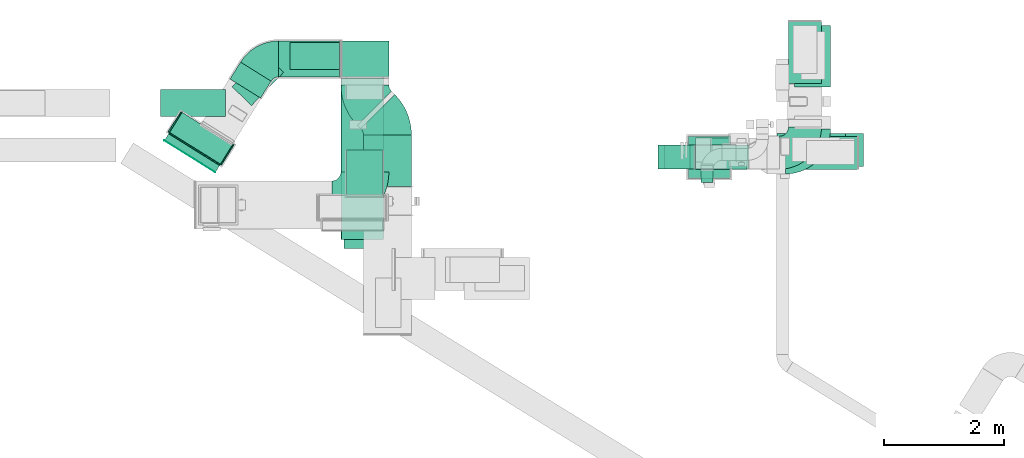
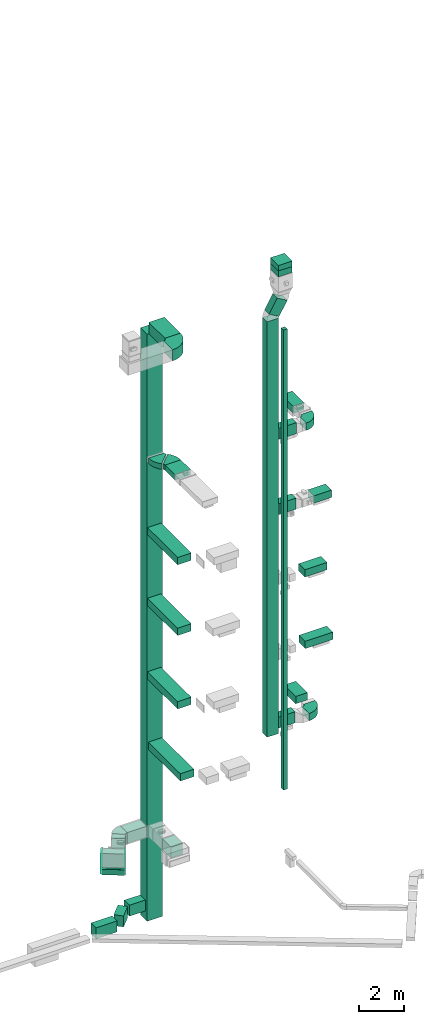
# One storey, part 6 of 29: 27 flow segments, 10 flow fittings, 1 flow terminal.
"""IFC2X3 building model written with IfcOpenShell, lengths in millimetres."""

from ifc_helpers import new_model, entity, si_unit, converted_unit, derived_unit, direction, frame, frame_2d, origin, origin_2d_with_axis, place, context, subcontext, project, spatial, polyline, circle_curve, parameter, trimmed, segment, composite_curve, rectangle, outline, extrude, faceted_brep, source, transform, mapped, material, type_object, type_shapes, element, save


model = new_model("IFC2X3")

# Units and contexts
model_context = context("Model", 3, precision=0.01, world=origin(), true_north=direction((6.12303176911189e-17, 1.0)))
body_context = subcontext(model_context, "Body", "Model", "MODEL_VIEW")
ifc_project = project(units=[si_unit("LENGTHUNIT", "METRE", prefix="MILLI"), si_unit("AREAUNIT", "SQUARE_METRE"), si_unit("VOLUMEUNIT", "CUBIC_METRE"), converted_unit("PLANEANGLEUNIT", "DEGREE", entity("IfcRatioMeasure", 0.0174532925199433), si_unit("PLANEANGLEUNIT", "RADIAN"), dimensions=[0, 0, 0, 0, 0, 0, 0]), si_unit("MASSUNIT", "GRAM", prefix="KILO"), derived_unit("MASSDENSITYUNIT", [(si_unit("MASSUNIT", "GRAM", prefix="KILO"), 1), (si_unit("LENGTHUNIT", "METRE"), -3)]), derived_unit("MOMENTOFINERTIAUNIT", [(si_unit("LENGTHUNIT", "METRE"), 4)]), si_unit("TIMEUNIT", "SECOND"), si_unit("FREQUENCYUNIT", "HERTZ"), si_unit("THERMODYNAMICTEMPERATUREUNIT", "DEGREE_CELSIUS"), derived_unit("THERMALTRANSMITTANCEUNIT", [(si_unit("MASSUNIT", "GRAM", prefix="KILO"), 1), (si_unit("THERMODYNAMICTEMPERATUREUNIT", "KELVIN"), -1), (si_unit("TIMEUNIT", "SECOND"), -3)]), derived_unit("VOLUMETRICFLOWRATEUNIT", [(si_unit("LENGTHUNIT", "METRE"), 3), (si_unit("TIMEUNIT", "SECOND"), -1)]), derived_unit("MASSFLOWRATEUNIT", [(si_unit("MASSUNIT", "GRAM", prefix="KILO"), 1), (si_unit("TIMEUNIT", "SECOND"), -1)]), derived_unit("ROTATIONALFREQUENCYUNIT", [(si_unit("TIMEUNIT", "SECOND"), -1)]), si_unit("ELECTRICCURRENTUNIT", "AMPERE"), si_unit("ELECTRICVOLTAGEUNIT", "VOLT"), si_unit("POWERUNIT", "WATT"), si_unit("FORCEUNIT", "NEWTON", prefix="KILO"), si_unit("ILLUMINANCEUNIT", "LUX"), si_unit("LUMINOUSFLUXUNIT", "LUMEN"), si_unit("LUMINOUSINTENSITYUNIT", "CANDELA"), derived_unit("USERDEFINED", [(si_unit("MASSUNIT", "GRAM", prefix="KILO"), -1), (si_unit("LENGTHUNIT", "METRE"), -2), (si_unit("TIMEUNIT", "SECOND"), 3), (si_unit("LUMINOUSFLUXUNIT", "LUMEN"), 1)]), derived_unit("LINEARVELOCITYUNIT", [(si_unit("LENGTHUNIT", "METRE"), 1), (si_unit("TIMEUNIT", "SECOND"), -1)]), si_unit("PRESSUREUNIT", "PASCAL"), derived_unit("USERDEFINED", [(si_unit("LENGTHUNIT", "METRE"), -2), (si_unit("MASSUNIT", "GRAM", prefix="KILO"), 1), (si_unit("TIMEUNIT", "SECOND"), -2)]), derived_unit("LINEARFORCEUNIT", [(si_unit("MASSUNIT", "GRAM", prefix="KILO"), 1), (si_unit("LENGTHUNIT", "METRE"), 1), (si_unit("TIMEUNIT", "SECOND"), -2), (si_unit("LENGTHUNIT", "METRE"), -1)]), derived_unit("PLANARFORCEUNIT", [(si_unit("MASSUNIT", "GRAM", prefix="KILO"), 1), (si_unit("LENGTHUNIT", "METRE"), 1), (si_unit("TIMEUNIT", "SECOND"), -2), (si_unit("LENGTHUNIT", "METRE"), -2)])], contexts=[model_context])

# Site, building, storey
site_placement = place(None, frame((0.0, -0.00077364408347762, 0.0)))
site = spatial("IfcSite", under=ifc_project, at=site_placement, CompositionType="ELEMENT")
building_placement = place(site_placement, origin())
building = spatial("IfcBuilding", under=site, at=building_placement, CompositionType="ELEMENT")
storey_placement = place(building_placement, origin())
storey = spatial("IfcBuildingStorey", under=building, at=storey_placement, CompositionType="ELEMENT", Elevation=0.0)

# Flow segments
duct_segment_type_1 = type_object("IfcDuctSegmentType", PredefinedType="NOTDEFINED")
flow_segment_1_placement = place(storey_placement, frame((10049.7340134019, 14594.0835453812, 7185.13492759623)))
element("IfcFlowSegment", 1, at=flow_segment_1_placement, inside=storey, type_object=duct_segment_type_1, context=body_context, shape_type="SweptSolid", body=[
    extrude(rectangle(XDim=896.28958332103, YDim=400.0, at=origin_2d_with_axis()), frame((448.144791660515, 200.0, 0.0), z_axis=(0.0, 0.0, 1.0), x_axis=(-1.0, 0.0, 0.0)), (0.0, 0.0, 1.0), 600.0),
])
flow_segment_2_placement = place(storey_placement, frame((10049.7340134019, 14469.5640511156, 18900.0)))
element("IfcFlowSegment", 2, at=flow_segment_2_placement, inside=storey, type_object=duct_segment_type_1, context=body_context, shape_type="SweptSolid", body=[
    extrude(rectangle(XDim=860.000000000108, YDim=400.0, at=origin_2d_with_axis()), frame((430.0, 200.0, 0.0)), (0.0, 0.0, 1.0), 599.999999999998),
])
flow_segment_3_placement = place(storey_placement, frame((11848.4871552699, 14469.5640511154, 18900.0)))
element("IfcFlowSegment", 3, at=flow_segment_3_placement, inside=storey, type_object=duct_segment_type_1, context=body_context, shape_type="SweptSolid", body=[
    extrude(rectangle(XDim=897.282341040552, YDim=550.000000000001, at=frame_2d((-1.08002495835535e-12, 0.0), x_axis=(1.0, 0.0))), frame((448.641170520277, 275.0, 0.0)), (0.0, 0.0, 1.0), 400.0),
])
flow_segment_4_placement = place(storey_placement, frame((10049.7340134019, 14472.5640511155, 23000.0)))
element("IfcFlowSegment", 4, at=flow_segment_4_placement, inside=storey, type_object=duct_segment_type_1, context=body_context, shape_type="SweptSolid", body=[
    extrude(rectangle(XDim=896.035482908388, YDim=400.0, at=frame_2d((1.08002495835535e-12, 1.09423581307055e-12), x_axis=(1.0, 0.0))), frame((448.017741454193, 200.0, 0.0)), (0.0, 0.0, 1.0), 600.000000000002),
])
flow_segment_5_placement = place(storey_placement, frame((11599.6422610433, 15901.4858452885, 23000.0)))
element("IfcFlowSegment", 5, at=flow_segment_5_placement, inside=storey, type_object=duct_segment_type_1, context=body_context, shape_type="SweptSolid", body=[
    extrude(rectangle(XDim=1032.28234104056, YDim=550.000000000001, at=frame_2d((1.08002495835535e-12, 0.0), x_axis=(1.0, 0.0))), frame((275.0, 516.141170520279, 0.0), z_axis=(0.0, 0.0, 1.0), x_axis=(0.0, 1.0, 0.0)), (0.0, 0.0, 1.0), 399.999999999996),
])
flow_segment_6_placement = place(storey_placement, frame((10144.7174683872, 14250.8402530396, 4000.0)))
element("IfcFlowSegment", 6, at=flow_segment_6_placement, inside=storey, type_object=duct_segment_type_1, context=body_context, shape_type="SweptSolid", body=[
    extrude(rectangle(XDim=199.999999999998, YDim=200.0, at=frame_2d((1.08713038571295e-12, 0.0), x_axis=(1.0, 0.0))), frame((100.0, 100.0, 0.0), z_axis=(0.0, 0.0, 1.0), x_axis=(0.0, -1.0, 0.0)), (0.0, 0.0, 1.0), 25050.0),
])
flow_segment_7_placement = place(storey_placement, frame((9429.73401340191, 14472.5640511154, 7000.0)))
element("IfcFlowSegment", 7, at=flow_segment_7_placement, inside=storey, type_object=duct_segment_type_1, context=body_context, shape_type="SweptSolid", body=[
    extrude(rectangle(XDim=400.0, YDim=600.0, at=frame_2d((0.0, 1.08002495835535e-12), x_axis=(1.0, 0.0))), frame((300.0, 200.0, 0.0), z_axis=(0.0, 0.0, 1.0), x_axis=(0.0, 1.0, 0.0)), (0.0, 0.0, 1.0), 22618.0236689535),
])
flow_segment_8_placement = place(storey_placement, frame((1285.71170920467, 14551.0540027881, 2050.0)))
element("IfcFlowSegment", 8, at=flow_segment_8_placement, inside=storey, type_object=duct_segment_type_1, context=body_context, shape_type="SweptSolid", body=[
    extrude(rectangle(XDim=1000.0, YDim=400.000000000001, at=frame_2d((-5.6843418860808e-13, 9.2370555648813e-13), x_axis=(1.0, 0.0))), frame((530.007900914171, 434.569251383529, 0.0), z_axis=(0.0, 0.0, 1.0), x_axis=(0.848048096097044, -0.529919264328235, 0.0)), (0.0, 0.0, 1.0), 1100.0),
])
flow_segment_9_placement = place(storey_placement, frame((11423.6279861459, 14520.0835453812, 11100.0)))
element("IfcFlowSegment", 9, at=flow_segment_9_placement, inside=storey, type_object=duct_segment_type_1, context=body_context, shape_type="SweptSolid", body=[
    extrude(rectangle(XDim=1424.85916912395, YDim=550.000000000001, at=origin_2d_with_axis()), frame((712.429584561975, 275.0, 0.0)), (0.0, 0.0, 1.0), 400.0),
])
flow_segment_10_placement = place(storey_placement, frame((11408.6279789287, 14519.0835453812, 15000.0)))
element("IfcFlowSegment", 10, at=flow_segment_10_placement, inside=storey, type_object=duct_segment_type_1, context=body_context, shape_type="SweptSolid", body=[
    extrude(rectangle(XDim=1142.14151738165, YDim=550.000000000001, at=frame_2d((0.0, 2.1600499167107e-12), x_axis=(1.0, 0.0))), frame((571.070758690827, 275.0, 0.0), z_axis=(0.0, 0.0, 1.0), x_axis=(-1.0, 0.0, 0.0)), (0.0, 0.0, 1.0), 400.0),
])
flow_segment_11_placement = place(storey_placement, frame((11700.2194386705, 15840.3805781062, 7200.0)))
element("IfcFlowSegment", 11, at=flow_segment_11_placement, inside=storey, type_object=duct_segment_type_1, context=body_context, shape_type="SweptSolid", body=[
    extrude(rectangle(XDim=1025.0, YDim=600.0, at=frame_2d((0.0, 1.08002495835535e-12), x_axis=(1.0, 0.0))), frame((300.0, 512.5, 0.0), z_axis=(0.0, 0.0, 1.0), x_axis=(0.0, 1.0, 0.0)), (0.0, 0.0, 1.0), 400.0),
])
flow_segment_12_placement = place(storey_placement, frame((9532.39994495478, 14472.5640511154, 29693.7755280271)))
element("IfcFlowSegment", 12, at=flow_segment_12_placement, inside=storey, type_object=duct_segment_type_1, context=body_context, shape_type="SweptSolid", body=[
    extrude(rectangle(XDim=600.000000000002, YDim=400.000000000002, at=frame_2d((-1.09423581307055e-12, 9.37916411203332e-13), x_axis=(0.0, 1.0))), frame((258.933627378855, 200.0, 151.503718147211), z_axis=(0.505012393824036, 0.0, 0.863112091262842), x_axis=(0.0, 1.0, 0.0)), (0.0, 0.0, 1.0), 845.129520297064),
])
flow_segment_13_placement = place(storey_placement, frame((9929.73401340183, 14322.5640511154, 31980.0)))
element("IfcFlowSegment", 13, at=flow_segment_13_placement, inside=storey, type_object=duct_segment_type_1, context=body_context, shape_type="SweptSolid", body=[
    extrude(rectangle(XDim=700.000000000001, YDim=699.999999999999, at=frame_2d((-1.08002495835535e-12, 0.0), x_axis=(1.0, 0.0))), frame((350.0, 350.0, 0.0), z_axis=(0.0, 0.0, 1.0), x_axis=(0.0, 1.0, 0.0)), (0.0, 0.0, 1.0), 320.64365169538),
])
duct_segment_type_2 = type_object("IfcDuctSegmentType", PredefinedType="NOTDEFINED")
flow_segment_14_placement = place(storey_placement, frame((4143.3305169552, 14427.5681314502, 30000.0)))
element("IfcFlowSegment", 14, at=flow_segment_14_placement, inside=storey, type_object=duct_segment_type_2, context=body_context, shape_type="SweptSolid", body=[
    extrude(rectangle(XDim=1432.40750074229, YDim=800.0, at=frame_2d((-1.13686837721616e-12, 0.0), x_axis=(1.0, 0.0))), frame((400.0, 716.203750371147, 0.0), z_axis=(0.0, 0.0, 1.0), x_axis=(0.0, -1.0, 0.0)), (0.0, 0.0, 1.0), 600.000000000002),
])
flow_segment_15_placement = place(storey_placement, frame((4143.33051695439, 16009.975632191, -2100.0)))
element("IfcFlowSegment", 15, at=flow_segment_15_placement, inside=storey, type_object=duct_segment_type_2, context=body_context, shape_type="SweptSolid", body=[
    extrude(rectangle(XDim=599.999999999998, YDim=800.0, at=frame_2d((1.08002495835535e-12, 0.0), x_axis=(1.0, 0.0))), frame((400.0, 300.0, 0.0), z_axis=(0.0, 0.0, 1.0), x_axis=(0.0, 1.0, 0.0)), (0.0, 0.0, 1.0), 31950.0),
])
flow_segment_16_placement = place(storey_placement, frame((4519.66175990126, 14181.608746557, 22900.0)))
element("IfcFlowSegment", 16, at=flow_segment_16_placement, inside=storey, type_object=duct_segment_type_2, context=body_context, shape_type="SweptSolid", body=[
    extrude(rectangle(XDim=862.182540694804, YDim=800.0, at=frame_2d((1.08002495835535e-12, -5.40012479177676e-13), x_axis=(1.0, 0.0))), frame((400.0, 431.091270347508, 0.0), z_axis=(0.0, 0.0, 1.0), x_axis=(0.0, 1.0, 0.0)), (0.0, 0.0, 1.0), 300.000000000001),
])
flow_segment_17_placement = place(storey_placement, frame((4150.45036991614, 13299.6581969188, 18950.0)))
element("IfcFlowSegment", 17, at=flow_segment_17_placement, inside=storey, type_object=duct_segment_type_2, context=body_context, shape_type="SweptSolid", body=[
    extrude(rectangle(XDim=2690.31743527313, YDim=700.0, at=frame_2d((0.0, -2.55795384873636e-13), x_axis=(1.0, 0.0))), frame((350.0, 1345.15871763657, 0.0), z_axis=(0.0, 0.0, 1.0), x_axis=(0.0, 1.0, 0.0)), (0.0, 0.0, 1.0), 400.0),
])
flow_segment_18_placement = place(storey_placement, frame((4199.45036991613, 13150.4683688133, 7250.0)))
element("IfcFlowSegment", 18, at=flow_segment_18_placement, inside=storey, type_object=duct_segment_type_2, context=body_context, shape_type="SweptSolid", body=[
    extrude(rectangle(XDim=2839.50726337812, YDim=700.0, at=frame_2d((-1.13686837721616e-12, 5.40012479177676e-13), x_axis=(1.0, 0.0))), frame((350.0, 1419.75363168906, 0.0), z_axis=(0.0, 0.0, 1.0), x_axis=(0.0, 1.0, 0.0)), (0.0, 0.0, 1.0), 400.0),
])
flow_segment_19_placement = place(storey_placement, frame((4149.45036991614, 13299.6581969188, 11100.0)))
element("IfcFlowSegment", 19, at=flow_segment_19_placement, inside=storey, type_object=duct_segment_type_2, context=body_context, shape_type="SweptSolid", body=[
    extrude(rectangle(XDim=2690.31743527277, YDim=700.0, at=frame_2d((0.0, -2.55795384873636e-13), x_axis=(1.0, 0.0))), frame((350.0, 1345.15871763639, 0.0), z_axis=(0.0, 0.0, 1.0), x_axis=(0.0, 1.0, 0.0)), (0.0, 0.0, 1.0), 400.0),
])
flow_segment_20_placement = place(storey_placement, frame((4150.45036991614, 13299.6581969188, 15100.0)))
element("IfcFlowSegment", 20, at=flow_segment_20_placement, inside=storey, type_object=duct_segment_type_2, context=body_context, shape_type="SweptSolid", body=[
    extrude(rectangle(XDim=2690.31743527295, YDim=700.0, at=frame_2d((-1.13686837721616e-12, -2.55795384873636e-13), x_axis=(1.0, 0.0))), frame((350.0, 1345.15871763648, 0.0), z_axis=(0.0, 0.0, 1.0), x_axis=(0.0, 1.0, 0.0)), (0.0, 0.0, 1.0), 400.0),
])
flow_segment_21_placement = place(storey_placement, frame((4238.73846384671, 14052.5, 2500.0)))
element("IfcFlowSegment", 21, at=flow_segment_21_placement, inside=storey, type_object=duct_segment_type_2, context=body_context, shape_type="SweptSolid", body=[
    extrude(rectangle(XDim=738.844290776113, YDim=600.0, at=origin_2d_with_axis()), frame((300.0, 369.422145388058, 0.0), z_axis=(0.0, 0.0, 1.0), x_axis=(0.0, -1.0, 0.0)), (0.0, 0.0, 1.0), 600.0),
])
flow_segment_22_placement = place(storey_placement, frame((3108.61579884427, 16009.9756321925, 2485.0)))
element("IfcFlowSegment", 22, at=flow_segment_22_placement, inside=storey, type_object=duct_segment_type_2, context=body_context, shape_type="SweptSolid", body=[
    extrude(rectangle(XDim=1014.71471811025, YDim=600.0, at=frame_2d((0.0, 1.08002495835535e-12), x_axis=(1.0, 0.0))), frame((507.357359055123, 300.0, 0.0), z_axis=(0.0, 0.0, 1.0), x_axis=(-1.0, 0.0, 0.0)), (0.0, 0.0, 1.0), 600.0),
])
flow_segment_23_placement = place(storey_placement, frame((1205.05402974284, 14422.633316354, 2100.0)))
element("IfcFlowSegment", 23, at=flow_segment_23_placement, inside=storey, type_object=duct_segment_type_2, context=body_context, shape_type="SweptSolid", body=[
    extrude(rectangle(XDim=131.648976761312, YDim=1000.0, at=frame_2d((9.16600129130529e-13, 5.6843418860808e-13), x_axis=(1.0, 0.0))), frame((458.905712529418, 320.781964168288, 0.0), z_axis=(0.0, 0.0, 1.0), x_axis=(0.529919264233203, 0.848048096156427, 0.0)), (0.0, 0.0, 1.0), 300.0),
])
flow_segment_24_placement = place(storey_placement, frame((3296.5333327933, 16131.8209502161, -1600.0)))
element("IfcFlowSegment", 24, at=flow_segment_24_placement, inside=storey, type_object=duct_segment_type_2, context=body_context, shape_type="SweptSolid", body=[
    extrude(rectangle(XDim=826.797184161113, YDim=449.999999999999, at=frame_2d((-2.8421709430404e-13, 1.08002495835535e-12), x_axis=(1.0, 0.0))), frame((413.398592080557, 225.0, 0.0), z_axis=(0.0, 0.0, 1.0), x_axis=(-1.0, 0.0, 0.0)), (0.0, 0.0, 1.0), 600.0),
])
flow_segment_25_placement = place(storey_placement, frame((2331.18103775171, 15533.3070422821, -1600.0)))
element("IfcFlowSegment", 25, at=flow_segment_25_placement, inside=storey, type_object=duct_segment_type_2, context=body_context, shape_type="SweptSolid", body=[
    extrude(rectangle(XDim=768.361021095479, YDim=450.000000000001, at=frame_2d((9.66338120633736e-13, 5.54223333892878e-13), x_axis=(1.0, 0.0))), frame((428.725662495396, 432.65446510469, 0.0), z_axis=(0.0, 0.0, 1.0), x_axis=(-0.694658370458998, -0.719339800338651, 0.0)), (0.0, 0.0, 1.0), 600.0),
])
flow_segment_26_placement = place(storey_placement, frame((2297.27259299581, 15658.9134625432, 2485.0)))
element("IfcFlowSegment", 26, at=flow_segment_26_placement, inside=storey, type_object=duct_segment_type_2, context=body_context, shape_type="SweptSolid", body=[
    extrude(rectangle(XDim=330.818571009889, YDim=600.0, at=frame_2d((1.05160324892495e-12, 3.41060513164848e-13), x_axis=(1.0, 0.0))), frame((342.067995716955, 299.250808947712, 0.0), z_axis=(0.0, 0.0, 1.0), x_axis=(-0.529919264328237, -0.848048096097043, 0.0)), (0.0, 0.0, 1.0), 600.0),
])
flow_segment_27_placement = place(storey_placement, frame((1140.10630979671, 15350.1020645575, -1600.0)))
element("IfcFlowSegment", 27, at=flow_segment_27_placement, inside=storey, type_object=duct_segment_type_2, context=body_context, shape_type="SweptSolid", body=[
    extrude(rectangle(XDim=1083.1737579042, YDim=449.999999999999, at=frame_2d((5.6843418860808e-14, -1.08002495835535e-12), x_axis=(1.0, 0.0))), frame((541.586878952102, 225.0, 0.0), z_axis=(0.0, 0.0, 1.0), x_axis=(-1.0, 0.0, 0.0)), (0.0, 0.0, 1.0), 600.0),
])

# Flow fitting
ifc_material_1 = material()
duct_fitting_type_1 = type_object("IfcDuctFittingType", PredefinedType="NOTDEFINED", material=ifc_material_1)
shared_shape_1 = source(origin(), body_context, "Body", "SweptSolid", [
    extrude(outline(composite_curve([segment(polyline([(-525.0, -225.0), (75.0, -225.0)]), True, "CONTINUOUS"), segment(trimmed(circle_curve(frame_2d((225.0, -225.0), x_axis=(0.0, 1.0)), 150.0), [parameter(0.0)], [parameter(90.0)], True, "PARAMETER"), False, "CONTINUOUS"), segment(polyline([(225.0, -75.0), (225.0, 525.0)]), True, "CONTINUOUS"), segment(trimmed(circle_curve(frame_2d((225.0, -225.0), x_axis=(0.0, 1.0)), 750.0), [parameter(0.0)], [parameter(90.0)], True, "PARAMETER"), True, "CONTINUOUS")], self_intersect=False)), frame((-225.0, 225.0, -200.0), z_axis=(0.0, 0.0, 1.0), x_axis=(-1.0, 0.0, 0.0)), (0.0, 0.0, 1.0), 400.0),
])
type_shapes(duct_fitting_type_1, [shared_shape_1])
flow_fitting_1_placement = place(storey_placement, frame((12000.2194386704, 14694.0835453811, 7400.0)))
element("IfcFlowFitting", 28, at=flow_fitting_1_placement, inside=storey, type_object=duct_fitting_type_1, material=ifc_material_1, context=body_context, shape_type="MappedRepresentation", body=[
    mapped(shared_shape_1, transform((0.0, 0.0, 0.0), scale=1.0)),
])

# Flow terminal
ifc_material_2 = material()
air_terminal_type = type_object("IfcAirTerminalType", PredefinedType="NOTDEFINED", material=ifc_material_2)
shared_shape_2 = source(origin(), body_context, "Body", "SweptSolid", [
    extrude(rectangle(XDim=4.0, YDim=999.999999999999, at=origin_2d_with_axis()), frame((0.0, -2.0, -150.0), z_axis=(0.0, 0.0, 1.0), x_axis=(0.0, 1.0, 0.0)), (0.0, 0.0, 1.0), 300.000000000005),
])
type_shapes(air_terminal_type, [shared_shape_2])
flow_terminal_placement = place(storey_placement, frame((1629.07807782105, 14687.5929484706, 2250.0), z_axis=(0.0, 0.0, -1.0), x_axis=(-0.848048096156392, 0.52991926423326, 0.0)))
element("IfcFlowTerminal", 29, at=flow_terminal_placement, inside=storey, type_object=air_terminal_type, material=ifc_material_2, context=body_context, shape_type="MappedRepresentation", body=[
    mapped(shared_shape_2, transform((0.0, 0.0, 0.0), scale=1.0)),
])

# Flow fittings
duct_fitting_type_2 = type_object("IfcDuctFittingType", PredefinedType="NOTDEFINED", material=ifc_material_1)
shared_shape_3 = source(origin(), body_context, "Body", "SweptSolid", [
    extrude(outline(composite_curve([segment(polyline([(-675.0, -275.0), (125.0, -275.0)]), True, "CONTINUOUS"), segment(trimmed(circle_curve(frame_2d((275.0, -275.0), x_axis=(0.0, 1.0)), 150.0), [parameter(0.0)], [parameter(90.0)], True, "PARAMETER"), False, "CONTINUOUS"), segment(polyline([(275.0, -125.0), (275.0, 675.0)]), True, "CONTINUOUS"), segment(trimmed(circle_curve(frame_2d((275.0, -275.0), x_axis=(0.0, 1.0)), 950.0), [parameter(0.0)], [parameter(89.9999999999999)], True, "PARAMETER"), True, "CONTINUOUS")], self_intersect=False)), frame((-275.0, 275.0, -300.0), z_axis=(0.0, 0.0, 1.0), x_axis=(-1.0, 0.0, 0.0)), (0.0, 0.0, 1.0), 600.0),
])
type_shapes(duct_fitting_type_2, [shared_shape_3])
flow_fitting_2_placement = place(storey_placement, frame((4543.33051695519, 13877.5681314502, 30300.0)))
element("IfcFlowFitting", 30, at=flow_fitting_2_placement, inside=storey, type_object=duct_fitting_type_2, material=ifc_material_1, context=body_context, shape_type="MappedRepresentation", body=[
    mapped(shared_shape_3, transform((0.0, 0.0, 0.0), scale=1.0)),
])
duct_fitting_type_3 = type_object("IfcDuctFittingType", PredefinedType="NOTDEFINED", material=ifc_material_1)
shared_shape_4 = source(origin(), body_context, "Body", "SweptSolid", [
    extrude(rectangle(XDim=26.0960001120806, YDim=1000.0, at=frame_2d((-7.7715611723761e-13, -5.6843418860808e-14), x_axis=(1.0, 0.0))), frame((6.95199999999667, 0.0, -150.0)), (0.0, 0.0, 1.0), 300.0),
])
type_shapes(duct_fitting_type_3, [shared_shape_4])
flow_fitting_3_placement = place(storey_placement, frame((1709.43979203782, 14816.1985745446, 2250.0), z_axis=(0.0, 0.0, -1.0), x_axis=(-0.529919264233199, -0.84804809615643, 0.0)))
element("IfcFlowFitting", 31, at=flow_fitting_3_placement, inside=storey, type_object=duct_fitting_type_3, material=ifc_material_1, context=body_context, shape_type="MappedRepresentation", body=[
    mapped(shared_shape_4, transform((0.0, 0.0, 0.0), scale=1.0)),
])
duct_fitting_type_4 = type_object("IfcDuctFittingType", PredefinedType="NOTDEFINED", material=ifc_material_1)
shared_shape_5 = source(origin(), body_context, "Body", "SweptSolid", [
    extrude(rectangle(XDim=24.9999999999999, YDim=400.0, at=frame_2d((-1.63424829224823e-13, 0.0), x_axis=(1.0, 0.0))), frame((12.5000000000061, 0.0, -550.0)), (0.0, 0.0, 1.0), 1100.0),
])
type_shapes(duct_fitting_type_4, [shared_shape_5])
for number, where, z_axis, x_axis in (
    (32, (1391.69556207032, 15250.5828863358, 2600.0), (0.0, 0.0, 1.0), (-0.848048096097044, 0.529919264328235, 0.0)),
    (33, (2239.74365816737, 14720.6636220076, 2600.0), (0.0, 0.0, 1.0), (0.848048096097044, -0.529919264328235, 0.0)),
):
    element("IfcFlowFitting", number, at=place(storey_placement, frame(where, z_axis=z_axis, x_axis=x_axis)), inside=storey, type_object=duct_fitting_type_4, material=ifc_material_1, context=body_context, shape_type="MappedRepresentation", body=[
        mapped(shared_shape_5, transform((0.0, 0.0, 0.0), scale=1.0)),
    ])
duct_fitting_type_5 = type_object("IfcDuctFittingType", PredefinedType="NOTDEFINED", material=ifc_material_1)
shared_shape_6 = source(origin(), body_context, "Body", "SweptSolid", [
    extrude(outline(composite_curve([segment(polyline([(-405.768165526146, -190.810821621834), (194.231834473855, -190.810821621834)]), True, "CONTINUOUS"), segment(trimmed(circle_curve(frame_2d((344.231834473854, -190.810821621834), x_axis=(-0.529919264328242, 0.848048096097045)), 150.0), [parameter(0.0)], [parameter(57.9999999935792)], True, "PARAMETER"), False, "CONTINUOUS"), segment(polyline([(264.743944824618, -63.6036072072778), (-53.2076137723272, 445.225250450946)]), True, "CONTINUOUS"), segment(trimmed(circle_curve(frame_2d((344.231834473854, -190.810821621834), x_axis=(-0.529919264328242, 0.848048096097045)), 750.0), [parameter(0.0)], [parameter(57.9999999935792)], True, "PARAMETER"), True, "CONTINUOUS")], self_intersect=False)), frame((-58.6282514989433, 105.768165526137, -300.0), z_axis=(0.0, 0.0, 1.0), x_axis=(-0.84804809609704, 0.529919264328242, 0.0)), (0.0, 0.0, 1.0), 600.0),
])
type_shapes(duct_fitting_type_5, [shared_shape_6])
flow_fitting_4_placement = place(storey_placement, frame((2859.1767257235, 16309.9756321925, 2785.0), z_axis=(0.0, 0.0, 1.0), x_axis=(-1.0, 0.0, 0.0)))
element("IfcFlowFitting", 34, at=flow_fitting_4_placement, inside=storey, type_object=duct_fitting_type_5, material=ifc_material_1, context=body_context, shape_type="MappedRepresentation", body=[
    mapped(shared_shape_6, transform((0.0, 0.0, 0.0), scale=1.0)),
])
duct_fitting_type_6 = type_object("IfcDuctFittingType", PredefinedType="NOTDEFINED", material=ifc_material_1)
shared_shape_7 = source(origin(), body_context, "Body", "SweptSolid", [
    extrude(outline(composite_curve([segment(polyline([(-487.5, -212.5), (62.5000000000001, -212.5)]), True, "CONTINUOUS"), segment(trimmed(circle_curve(frame_2d((212.5, -212.5), x_axis=(0.0, 1.0)), 150.0), [parameter(0.0)], [parameter(90.0)], True, "PARAMETER"), False, "CONTINUOUS"), segment(polyline([(212.5, -62.4999999999998), (212.5, 487.5)]), True, "CONTINUOUS"), segment(trimmed(circle_curve(frame_2d((212.5, -212.5), x_axis=(0.0, 1.0)), 700.0), [parameter(0.0)], [parameter(90.0)], True, "PARAMETER"), True, "CONTINUOUS")], self_intersect=False)), frame((-212.499999999994, 212.499999999992, -200.0), z_axis=(0.0, 0.0, 1.0), x_axis=(-1.0, 0.0, 0.0)), (0.0, 0.0, 1.0), 400.0),
])
type_shapes(duct_fitting_type_6, [shared_shape_7])
flow_fitting_5_placement = place(storey_placement, frame((11874.6422610433, 14747.5640511155, 23200.0)))
element("IfcFlowFitting", 35, at=flow_fitting_5_placement, inside=storey, type_object=duct_fitting_type_6, material=ifc_material_1, context=body_context, shape_type="MappedRepresentation", body=[
    mapped(shared_shape_7, transform((0.0, 0.0, 0.0), scale=1.0)),
])
duct_fitting_type_7 = type_object("IfcDuctFittingType", PredefinedType="NOTDEFINED", material=ifc_material_1)
shared_shape_8 = source(origin(), body_context, "Body", "SweptSolid", [
    extrude(outline(composite_curve([segment(polyline([(-480.545635173699, -194.4543648263), (319.454364826301, -194.4543648263)]), True, "CONTINUOUS"), segment(trimmed(circle_curve(frame_2d((469.454364826301, -194.4543648263), x_axis=(-0.707106781186553, 0.707106781186553)), 150.0), [parameter(0.0)], [parameter(45.0)], True, "PARAMETER"), False, "CONTINUOUS"), segment(polyline([(363.388347648319, -88.3883476483182), (-202.29707730092, 477.297077300919)]), True, "CONTINUOUS"), segment(trimmed(circle_curve(frame_2d((469.454364826301, -194.4543648263), x_axis=(-0.707106781186553, 0.707106781186553)), 950.0), [parameter(0.0)], [parameter(45.0)], True, "PARAMETER"), True, "CONTINUOUS")], self_intersect=False)), frame((-33.363094478895, 80.545635173691, -150.0), z_axis=(0.0, 0.0, 1.0), x_axis=(-0.707106781186547, 0.707106781186548, 0.0)), (0.0, 0.0, 1.0), 300.0),
])
type_shapes(duct_fitting_type_7, [shared_shape_8])
for number, where, z_axis, x_axis in (
    (36, (4919.66175990148, 15271.6087465571, 23050.0), (0.0, 0.0, 1.0), (0.0, 1.0, 0.0)),
    (37, (4543.33051695517, 15647.9399895033, 23050.0), (0.0, 0.0, 1.0), (0.0, -1.0, 0.0)),
):
    element("IfcFlowFitting", number, at=place(storey_placement, frame(where, z_axis=z_axis, x_axis=x_axis)), inside=storey, type_object=duct_fitting_type_7, material=ifc_material_1, context=body_context, shape_type="MappedRepresentation", body=[
        mapped(shared_shape_8, transform((0.0, 0.0, 0.0), scale=1.0)),
    ])
duct_fitting_type_8 = type_object("IfcDuctFittingType", PredefinedType="NOTDEFINED", material=ifc_material_1)
shared_shape_9 = source(origin(), body_context, "Body", "Brep", [
    faceted_brep([(300.0, -355.0, 355.0), (300.0, -355.0, -355.0), (300.0, 355.0, -355.0), (300.0, 355.0, 355.0), (0.0, -350.0, 350.0), (0.0, 350.0, 350.0), (0.0, 350.0, -350.0), (0.0, -350.0, -350.0)], [[[0, 1, 2, 3]], [[4, 5, 6, 7]], [[4, 7, 1, 0]], [[7, 6, 2, 1]], [[6, 5, 3, 2]], [[5, 4, 0, 3]]]),
])
type_shapes(duct_fitting_type_8, [shared_shape_9])
flow_fitting_6_placement = place(storey_placement, frame((10279.7340134019, 14672.5640511154, 32300.6436516953), z_axis=(0.0, 1.0, 0.0), x_axis=(0.0, 0.0, 1.0)))
element("IfcFlowFitting", 38, at=flow_fitting_6_placement, inside=storey, type_object=duct_fitting_type_8, material=ifc_material_1, context=body_context, shape_type="MappedRepresentation", body=[
    mapped(shared_shape_9, transform((0.0, 0.0, 0.0), scale=1.0)),
])

save(model, "model.ifc")
